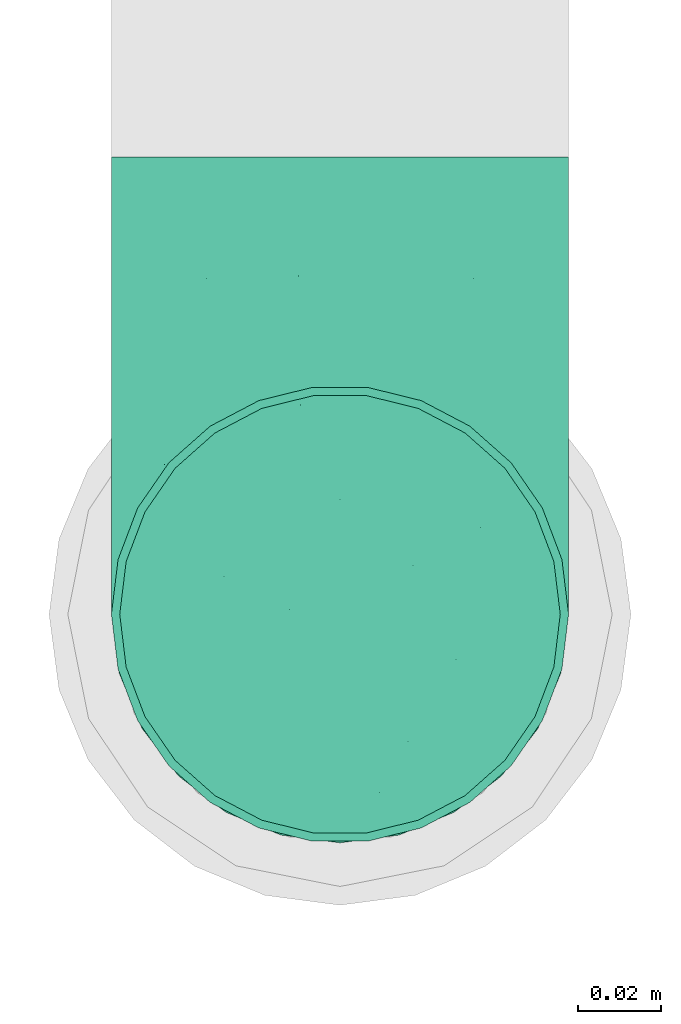
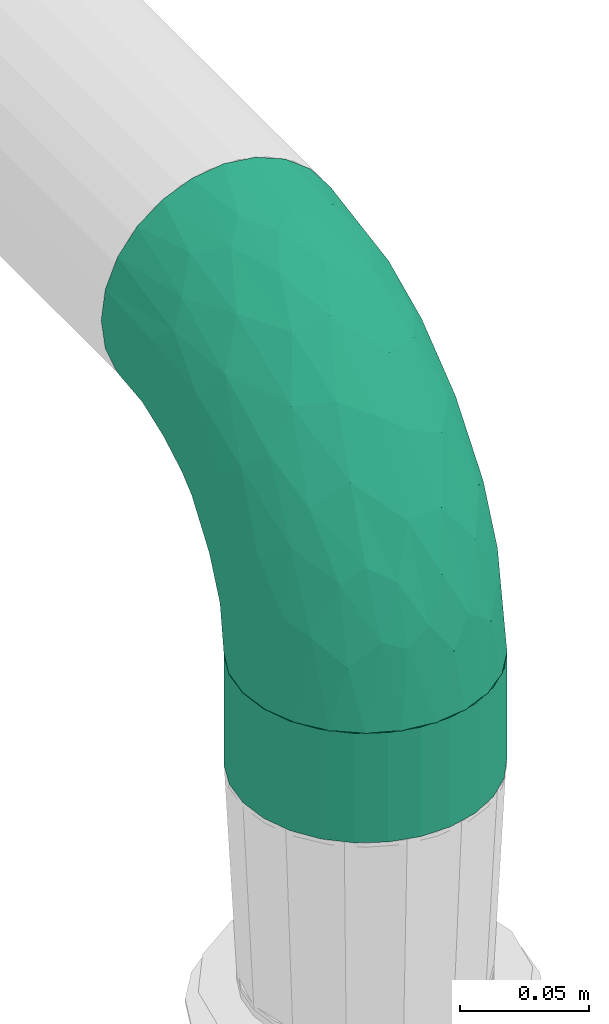
# One storey, part 49 of 123: 1 flow fitting, 1 flow segment.
"""IFC2X3 building model written with IfcOpenShell, lengths in millimetres."""

from ifc_helpers import new_model, entity, si_unit, converted_unit, derived_unit, direction, frame, origin_with_axes, origin_2d_with_axis, place, context, subcontext, project, spatial, hollow_circle, extrude, open_shell, surface_model, source, transform, mapped, material, layer, layer_set, layer_usage, type_object, element, save


model = new_model("IFC2X3")

# Units and contexts
model_context = context("Model", 3, precision=1e-05, world=origin_with_axes(), true_north=direction((0.0, 1.0)))
body_context = subcontext(model_context, "Body", "Model", "MODEL_VIEW")
ifc_project = project(units=[si_unit("AREAUNIT", "SQUARE_METRE"), si_unit("VOLUMEUNIT", "CUBIC_METRE", prefix="DECI"), si_unit("TIMEUNIT", "SECOND"), si_unit("THERMODYNAMICTEMPERATUREUNIT", "DEGREE_CELSIUS"), si_unit("PRESSUREUNIT", "PASCAL"), si_unit("MASSUNIT", "GRAM", prefix="KILO"), si_unit("LENGTHUNIT", "METRE", prefix="MILLI"), si_unit("POWERUNIT", "WATT"), si_unit("ELECTRICCURRENTUNIT", "AMPERE"), si_unit("ELECTRICVOLTAGEUNIT", "VOLT"), derived_unit("VOLUMETRICFLOWRATEUNIT", [(si_unit("VOLUMEUNIT", "CUBIC_METRE", prefix="DECI"), 1), (si_unit("TIMEUNIT", "SECOND"), -1)]), derived_unit("LINEARVELOCITYUNIT", [(si_unit("LENGTHUNIT", "METRE"), 1), (si_unit("TIMEUNIT", "SECOND"), -1)]), derived_unit("MASSDENSITYUNIT", [(si_unit("MASSUNIT", "GRAM", prefix="KILO"), 1), (si_unit("VOLUMEUNIT", "CUBIC_METRE"), -1)]), converted_unit("PLANEANGLEUNIT", "DEGREE", entity("IfcRatioMeasure", 0.01745), si_unit("PLANEANGLEUNIT", "RADIAN"), dimensions=[0, 0, 0, 0, 0, 0, 0])], contexts=[model_context])

# Site, building, storey
site_placement = place(None, origin_with_axes())
site = spatial("IfcSite", under=ifc_project, at=site_placement, CompositionType="ELEMENT")
building_placement = place(site_placement, origin_with_axes())
building = spatial("IfcBuilding", under=site, at=building_placement, Name="mc-building", CompositionType="ELEMENT")
storey_placement = place(building_placement, origin_with_axes())
storey = spatial("IfcBuildingStorey", under=building, at=storey_placement, Name="1. Korrus", CompositionType="ELEMENT", Elevation=0.0)

# Flow segment
ifc_material = material(Name="FZ1")
ifc_layer = layer(ifc_material, 0.0)
ifc_layer_set = layer_set([ifc_layer], Name="FZ1")
ifc_layer_usage = layer_usage(ifc_layer_set, "AXIS1", "POSITIVE", 0.0)
duct_segment_type = type_object("IfcDuctSegmentType", PredefinedType="RIGIDSEGMENT")
shared_shape_1 = source(origin_with_axes(), body_context, "Body", "SweptSolid", [
    extrude(hollow_circle(Radius=55.0, WallThickness=2.0, at=origin_2d_with_axis()), frame((0.0, 0.0, 0.0), z_axis=(1.0, 0.0, 0.0), x_axis=(0.0, 1.0, 0.0)), (0.0, 0.0, 1.0), 51.9),
])
flow_segment_placement = place(storey_placement, frame((7686.9773, 8583.57591, 2355.0), z_axis=(0.0, 1.0, 0.0), x_axis=(0.0, 0.0, -1.0)))
element("IfcFlowSegment", 1, at=flow_segment_placement, inside=storey, type_object=duct_segment_type, material=ifc_layer_usage, context=body_context, shape_type="MappedRepresentation", body=[
    mapped(shared_shape_1, transform((0.0, 0.0, 0.0), scale=1.0)),
])

# Flow fitting
duct_fitting_type = type_object("IfcDuctFittingType", Name="BU", PredefinedType="BEND")
shared_shape_2 = source(origin_with_axes(), body_context, "Body", "SurfaceModel", [
    surface_model("IfcShellBasedSurfaceModel", [(-110.0, 0.0, -55.0), (-110.0, -14.23505, -53.12592), (-110.0, 14.23505, -53.12592), (-110.0, 53.12592, 14.23505), (-110.0, 27.5, -47.63139), (-110.0, 38.89087, -38.89087), (-110.0, -55.0, 0.0), (-110.0, -53.12592, 14.23505), (-110.0, -38.89087, -38.89087), (-110.0, -27.5, -47.63139), (-110.0, -53.12592, -14.23505), (-110.0, -47.63139, -27.5), (-110.0, -14.23505, 53.12592), (-110.0, 14.23505, 53.12592), (-110.0, 27.5, 47.63139), (-110.0, -47.63139, 27.5), (-110.0, -38.89087, 38.89087), (-110.0, -27.5, 47.63139), (-110.0, 0.0, 55.0), (-110.0, 55.0, 0.0), (-110.0, 53.12592, -14.23505), (-110.0, 47.63139, -27.5), (-110.0, 47.63139, 27.5), (-110.0, 38.89087, 38.89087), (-14.23505, 110.0, -53.12592), (-55.0, 110.0, 0.0), (0.0, 110.0, -55.0), (-27.5, 110.0, -47.63139), (-38.89087, 110.0, -38.89087), (-47.63139, 110.0, -27.5), (38.89087, 110.0, -38.89087), (53.12592, 110.0, 14.23505), (27.5, 110.0, -47.63139), (14.23505, 110.0, -53.12592), (47.63139, 110.0, -27.5), (53.12592, 110.0, -14.23505), (55.0, 110.0, 0.0), (-53.12592, 110.0, -14.23505), (-53.12592, 110.0, 14.23505), (-47.63139, 110.0, 27.5), (-38.89087, 110.0, 38.89087), (-27.5, 110.0, 47.63139), (0.0, 110.0, 55.0), (-14.23505, 110.0, 53.12592), (38.89087, 110.0, 38.89087), (47.63139, 110.0, 27.5), (27.5, 110.0, 47.63139), (14.23505, 110.0, 53.12592), (-64.21732, 48.68956, 43.63444), (-76.6405, 38.18013, 45.55988), (-60.44912, 32.56953, 51.94617), (-76.00813, 5.38378, 55.0), (-90.15553, 11.94394, 54.09138), (-78.5998, 26.77405, 50.81338), (-70.18771, 18.55163, 54.03432), (-75.55424, 54.2118, 32.41257), (-93.27622, 45.77614, 33.48188), (-96.12334, 22.13664, 50.81337), (-21.00813, 45.34362, 55.0), (-18.36258, 70.48427, 54.04484), (-32.04182, 59.64019, 52.24446), (-63.88653, 74.77858, 17.99134), (-74.66383, 63.08407, 19.92123), (-63.60674, 66.07878, 29.97482), (-99.597, 52.72185, 18.52927), (-93.11138, 56.59448, 10.50359), (-98.21577, 57.34403, 0.0), (-53.42855, 92.60092, 21.04759), (-88.54852, 54.8376, 21.04759), (-11.86161, 90.23965, 54.10313), (-5.38378, 76.00813, 55.0), (-57.34403, 98.21577, 0.0), (-56.64619, 93.12774, 10.22088), (-45.34362, 21.00813, 55.0), (-44.60838, 44.60838, 52.13415), (-92.68484, 35.46673, 43.63443), (-22.25266, 95.40765, 50.81337), (-35.97783, 90.61597, 43.63443), (-43.70931, 69.58671, 44.47149), (-27.23711, 77.39884, 50.81337), (-57.2828, 79.3123, 24.9774), (-58.67786, 84.31125, 16.04456), (-82.93277, 60.36161, 12.91784), (-49.88337, 54.51816, 47.224), (-74.57753, 66.83759, 9.55742), (-45.35812, 94.97281, 33.48188), (-59.18663, 88.95241, 0.0), (-51.517, 78.6292, 33.48188), (-65.14788, 80.03077, 0.0), (-56.45322, 62.06476, 39.63545), (-88.95241, 59.18663, 0.0), (-71.10913, 71.10913, 0.0), (-80.03077, 65.14788, 0.0), (-94.9309, 45.36788, -33.48188), (-93.11358, 56.60141, -10.46614), (-99.64997, 52.79499, -18.30015), (-90.20425, 36.08686, -43.63443), (-79.99933, 46.56772, -37.92748), (-76.00813, 5.38378, -55.0), (-72.75364, 19.68651, -53.60527), (-45.34362, 21.00813, -55.0), (-21.91957, 65.12078, -53.85897), (-5.38378, 76.00813, -55.0), (-21.00813, 45.34362, -55.0), (-35.41876, 92.89265, -43.63443), (-91.10309, 11.02766, -54.21832), (-45.77614, 93.27622, -33.48188), (-90.50474, 23.21022, -50.81337), (-70.92854, 33.31794, -49.51754), (-78.52933, 63.35627, -11.73997), (-24.91508, 84.05606, -50.81337), (-88.78941, 54.74452, -21.04759), (-69.59921, 57.34866, -33.48187), (-73.36422, 62.46673, -22.94182), (-63.49062, 67.59111, -28.46929), (-56.59448, 93.11138, -10.50359), (-54.8376, 88.54852, -21.04759), (-54.10679, 75.85581, -32.31867), (-57.75956, 31.09612, -52.80882), (-52.72185, 99.597, -18.52927), (-12.62913, 89.46304, -53.99097), (-34.46825, 66.46123, -50.04329), (-43.9837, 43.9837, -52.42279), (-65.78527, 72.58348, -17.68796), (-70.34468, 43.65295, -44.21951), (-57.47001, 51.99467, -44.91465), (-60.72547, 82.29174, -12.88567), (-42.34915, 74.24548, -43.63444), (-57.25194, 63.5016, -38.08211), (-80.95344, 53.56991, -29.32027), (-52.32891, 4.55257, -54.0482), (32.52942, 47.13398, -30.48571), (14.88266, 20.92917, -33.7947), (14.95561, 36.05775, -42.26543), (30.24048, 70.09027, -41.7461), (19.3559, 65.35825, -48.00507), (-70.35075, -46.44478, -19.5952), (-47.13398, -32.52942, -30.48571), (-28.49299, -30.5778, -16.4009), (-4.55257, 52.32891, -54.0482), (-22.4954, 22.4954, -53.25347), (-75.47368, -11.22546, -52.60718), (-81.32209, -51.5606, -9.98467), (-80.81763, -41.84862, -32.14655), (-70.09027, -30.24048, -41.7461), (-36.05774, -14.95561, -42.26543), (-9.15831, -10.852, -27.8997), (-65.35825, -19.3559, -48.00507), (11.22546, 75.47368, -52.60718), (3.94376, 43.9333, -50.53315), (-13.39742, 13.39743, -48.13058), (-43.9333, -3.94376, -50.53315), (49.37776, 67.29486, 0.0), (41.8609, 47.82256, -9.92641), (50.20582, 74.51695, -9.9731), (18.93131, 11.7156, -17.56239), (-27.5, -32.89419, 0.0), (-1.23348, -12.25375, -12.18106), (41.84862, 80.81763, -32.14655), (35.70604, 41.31408, -20.38235), (46.44478, 70.35075, -19.5952), (32.89419, 27.5, 0.0), (6.67262, -6.67262, 0.0), (-67.29486, -49.37776, 0.0), (-50.36265, -42.95545, -9.51562), (-5.47251, 5.47251, -39.92906), (-70.35075, -46.44478, 19.5952), (-74.51695, -50.20582, 9.9731), (-41.31407, -35.70604, 20.38235), (-47.13398, -32.52942, 30.48571), (-80.81763, -41.84862, 32.14655), (-4.55257, 52.32891, 54.0482), (11.22546, 75.47368, 52.60718), (-43.9333, -3.94376, 50.53315), (-65.35825, -19.3559, 48.00507), (-36.05774, -14.95561, 42.26543), (-70.09027, -30.24048, 41.7461), (-11.7156, -18.93131, 17.56239), (30.5778, 28.49299, 16.4009), (12.25375, 1.23348, 12.18106), (51.5606, 81.32209, 9.98467), (42.95545, 50.36265, 9.51562), (-75.47368, -11.22546, 52.60718), (-52.32891, 4.55257, 54.0482), (3.94376, 43.9333, 50.53315), (-22.4954, 22.4954, 53.25347), (-13.39742, 13.39743, 48.13058), (10.852, 9.15831, 27.8997), (-20.92916, -14.88266, 33.79469), (-47.82256, -41.8609, 9.92641), (32.52942, 47.13398, 30.48571), (46.44478, 70.35075, 19.5952), (41.84862, 80.81763, 32.14655), (30.24048, 70.09027, 41.7461), (19.3559, 65.35825, 48.00507), (14.95561, 36.05775, 42.26543), (-5.47251, 5.47251, 39.92906)], [open_shell([[[0, 1, 2]], [[2, 3, 4]], [[4, 3, 5]], [[2, 6, 7]], [[8, 6, 9]], [[1, 9, 6]], [[10, 6, 11]], [[8, 11, 6]], [[6, 2, 1]], [[12, 13, 14]], [[15, 2, 7]], [[16, 17, 2]], [[2, 17, 12]], [[12, 18, 13]], [[19, 20, 3]], [[5, 3, 21]], [[20, 21, 3]], [[22, 3, 2]], [[23, 22, 2]], [[12, 14, 2]], [[2, 14, 23]], [[15, 16, 2]], [[24, 25, 26]], [[27, 25, 24]], [[25, 28, 29]], [[28, 25, 27]], [[30, 26, 31]], [[26, 30, 32]], [[32, 33, 26]], [[34, 31, 35]], [[31, 34, 30]], [[35, 31, 36]], [[29, 37, 25]], [[38, 39, 26]], [[39, 40, 26]], [[41, 42, 40]], [[42, 26, 40]], [[42, 41, 43]], [[26, 44, 45]], [[31, 26, 45]], [[26, 46, 44]], [[47, 46, 26]], [[42, 47, 26]], [[25, 38, 26]], [[48, 49, 50]], [[18, 51, 52]], [[53, 54, 50]], [[55, 56, 49]], [[56, 22, 23]], [[13, 57, 14]], [[58, 59, 60]], [[61, 62, 63]], [[3, 64, 65]], [[53, 52, 54]], [[3, 65, 66]], [[67, 39, 38]], [[56, 68, 64]], [[65, 64, 68]], [[69, 59, 70]], [[38, 71, 72]], [[73, 58, 74]], [[75, 49, 56]], [[76, 69, 43]], [[53, 57, 52]], [[77, 78, 79]], [[41, 76, 43]], [[43, 69, 42]], [[55, 68, 56]], [[23, 14, 75]], [[76, 77, 79]], [[80, 67, 81]], [[62, 82, 68]], [[60, 78, 83]], [[62, 84, 82]], [[85, 77, 40]], [[81, 67, 72]], [[86, 72, 71]], [[87, 85, 67]], [[61, 81, 88]], [[77, 41, 40]], [[78, 77, 87]], [[23, 75, 56]], [[83, 89, 48]], [[85, 40, 39]], [[62, 68, 55]], [[89, 87, 63]], [[83, 48, 50]], [[57, 75, 14]], [[49, 75, 53]], [[67, 85, 39]], [[87, 77, 85]], [[63, 62, 55]], [[89, 55, 48]], [[80, 63, 87]], [[66, 65, 90]], [[66, 19, 3]], [[84, 91, 92]], [[92, 90, 82]], [[65, 82, 90]], [[61, 84, 62]], [[92, 82, 84]], [[68, 82, 65]], [[3, 22, 64]], [[56, 64, 22]], [[38, 25, 71]], [[81, 72, 86]], [[38, 72, 67]], [[91, 61, 88]], [[80, 81, 61]], [[63, 80, 61]], [[67, 80, 87]], [[77, 76, 41]], [[79, 59, 69]], [[79, 69, 76]], [[42, 69, 70]], [[60, 59, 79]], [[58, 70, 59]], [[78, 60, 79]], [[58, 60, 74]], [[52, 57, 13]], [[75, 57, 53]], [[18, 52, 13]], [[52, 51, 54]], [[51, 73, 54]], [[50, 73, 74]], [[73, 50, 54]], [[50, 74, 83]], [[60, 83, 74]], [[89, 83, 78]], [[87, 89, 78]], [[55, 89, 63]], [[50, 49, 53]], [[55, 49, 48]], [[81, 86, 88]], [[91, 84, 61]], [[5, 21, 93]], [[90, 94, 66]], [[20, 94, 95]], [[96, 93, 97]], [[98, 99, 100]], [[96, 4, 5]], [[101, 102, 103]], [[28, 27, 104]], [[2, 105, 0]], [[104, 106, 28]], [[99, 105, 107]], [[108, 107, 96]], [[90, 109, 94]], [[107, 2, 4]], [[20, 66, 94]], [[27, 24, 110]], [[109, 111, 94]], [[112, 113, 114]], [[37, 115, 71]], [[116, 106, 117]], [[99, 118, 100]], [[116, 115, 119]], [[37, 119, 115]], [[24, 120, 110]], [[121, 110, 101]], [[119, 106, 116]], [[101, 110, 120]], [[122, 103, 100]], [[117, 123, 116]], [[124, 125, 108]], [[115, 116, 126]], [[106, 29, 28]], [[26, 102, 120]], [[127, 104, 110]], [[97, 124, 96]], [[125, 122, 118]], [[128, 127, 125]], [[96, 5, 93]], [[115, 126, 86]], [[117, 106, 127]], [[111, 113, 129]], [[95, 93, 21]], [[97, 129, 112]], [[110, 104, 27]], [[106, 104, 127]], [[96, 107, 4]], [[99, 107, 108]], [[99, 108, 118]], [[105, 99, 98]], [[112, 114, 128]], [[121, 125, 127]], [[20, 19, 66]], [[109, 90, 92]], [[94, 111, 95]], [[91, 123, 109]], [[129, 113, 112]], [[93, 95, 111]], [[21, 20, 95]], [[71, 115, 86]], [[71, 25, 37]], [[123, 91, 88]], [[126, 116, 123]], [[123, 88, 126]], [[86, 126, 88]], [[37, 29, 119]], [[106, 119, 29]], [[129, 93, 111]], [[124, 112, 125]], [[0, 105, 98]], [[107, 105, 2]], [[125, 118, 108]], [[100, 118, 122]], [[93, 129, 97]], [[113, 111, 109]], [[109, 123, 113]], [[114, 123, 117]], [[123, 114, 113]], [[128, 114, 117]], [[127, 128, 117]], [[112, 128, 125]], [[103, 122, 101]], [[110, 121, 127]], [[101, 122, 121]], [[125, 121, 122]], [[26, 120, 24]], [[101, 120, 102]], [[96, 124, 108]], [[92, 91, 109]], [[112, 124, 97]], [[100, 130, 98]], [[131, 132, 133]], [[32, 134, 135]], [[136, 137, 138]], [[139, 140, 103]], [[98, 141, 0]], [[142, 10, 136]], [[143, 144, 137]], [[6, 10, 142]], [[137, 145, 146]], [[144, 147, 145]], [[143, 136, 11]], [[11, 136, 10]], [[8, 143, 11]], [[148, 149, 139]], [[8, 9, 144]], [[9, 1, 147]], [[130, 141, 98]], [[103, 140, 100]], [[148, 135, 149]], [[150, 151, 140]], [[152, 153, 154]], [[130, 140, 151]], [[148, 26, 33]], [[147, 1, 141]], [[155, 146, 132]], [[156, 138, 157]], [[134, 30, 158]], [[150, 140, 149]], [[158, 30, 34]], [[30, 134, 32]], [[153, 159, 160]], [[131, 160, 159]], [[144, 145, 137]], [[36, 152, 154]], [[146, 138, 137]], [[155, 161, 162]], [[158, 160, 131]], [[133, 149, 135]], [[156, 163, 164]], [[163, 142, 164]], [[139, 103, 102]], [[153, 152, 161]], [[34, 35, 160]], [[162, 157, 155]], [[132, 165, 133]], [[157, 146, 155]], [[140, 130, 100]], [[141, 130, 151]], [[141, 151, 147]], [[141, 1, 0]], [[102, 26, 148]], [[140, 139, 149]], [[102, 148, 139]], [[135, 33, 32]], [[151, 150, 145]], [[9, 147, 144]], [[151, 145, 147]], [[145, 165, 146]], [[135, 148, 33]], [[133, 135, 134]], [[131, 133, 134]], [[133, 165, 150]], [[133, 150, 149]], [[145, 150, 165]], [[132, 131, 159]], [[146, 165, 132]], [[160, 158, 34]], [[134, 158, 131]], [[144, 143, 8]], [[136, 143, 137]], [[155, 153, 161]], [[154, 153, 160]], [[153, 155, 159]], [[132, 159, 155]], [[160, 35, 154]], [[36, 154, 35]], [[164, 136, 138]], [[6, 142, 163]], [[136, 164, 142]], [[156, 164, 138]], [[156, 157, 162]], [[146, 157, 138]], [[15, 7, 166]], [[6, 163, 167]], [[168, 169, 166]], [[166, 169, 170]], [[171, 172, 70]], [[173, 174, 175]], [[17, 176, 174]], [[177, 156, 162]], [[176, 16, 170]], [[170, 16, 15]], [[161, 178, 179]], [[152, 180, 181]], [[182, 173, 183]], [[18, 12, 182]], [[184, 185, 186]], [[183, 185, 73]], [[183, 73, 51]], [[177, 187, 188]], [[189, 168, 166]], [[187, 178, 190]], [[16, 176, 17]], [[161, 152, 181]], [[45, 191, 31]], [[45, 44, 192]], [[192, 191, 45]], [[180, 36, 31]], [[193, 194, 195]], [[46, 47, 194]], [[193, 195, 190]], [[193, 44, 46]], [[172, 42, 70]], [[185, 58, 73]], [[189, 163, 156]], [[163, 189, 167]], [[70, 58, 171]], [[184, 171, 185]], [[169, 188, 175]], [[180, 31, 191]], [[192, 193, 190]], [[191, 190, 178]], [[182, 174, 173]], [[194, 47, 172]], [[190, 195, 187]], [[186, 185, 173]], [[162, 179, 177]], [[188, 196, 175]], [[179, 187, 177]], [[185, 171, 58]], [[172, 171, 184]], [[172, 184, 194]], [[172, 47, 42]], [[51, 18, 182]], [[185, 183, 173]], [[51, 182, 183]], [[174, 12, 17]], [[184, 186, 195]], [[46, 194, 193]], [[184, 195, 194]], [[195, 196, 187]], [[174, 182, 12]], [[175, 174, 176]], [[169, 175, 176]], [[175, 196, 186]], [[175, 186, 173]], [[195, 186, 196]], [[188, 169, 168]], [[187, 196, 188]], [[166, 170, 15]], [[176, 170, 169]], [[193, 192, 44]], [[191, 192, 190]], [[177, 189, 156]], [[167, 189, 166]], [[189, 177, 168]], [[188, 168, 177]], [[166, 7, 167]], [[6, 167, 7]], [[181, 191, 178]], [[36, 180, 152]], [[191, 181, 180]], [[161, 181, 178]], [[161, 179, 162]], [[187, 179, 178]]])]),
])
flow_fitting_placement = place(storey_placement, frame((7686.9773, 8583.57591, 2465.0), z_axis=(1.0, 0.0, 0.0), x_axis=(0.0, -1.0, 0.0)))
element("IfcFlowFitting", 2, at=flow_fitting_placement, inside=storey, type_object=duct_fitting_type, Name="BU", context=body_context, shape_type="MappedRepresentation", body=[
    mapped(shared_shape_2, transform((0.0, 0.0, 0.0), scale=1.0)),
])

save(model, "model.ifc")
